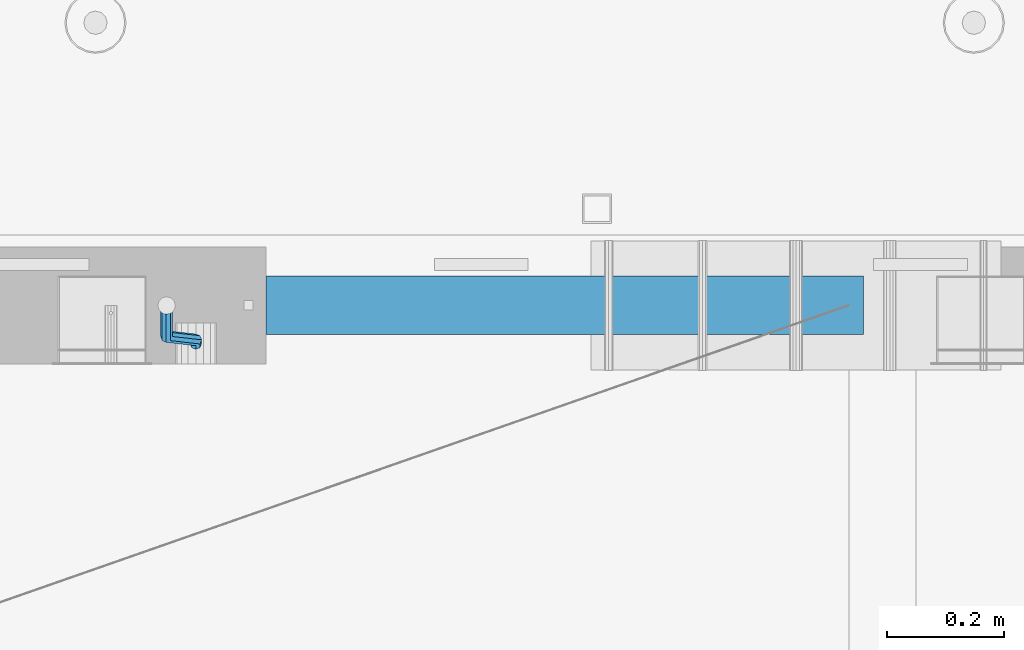
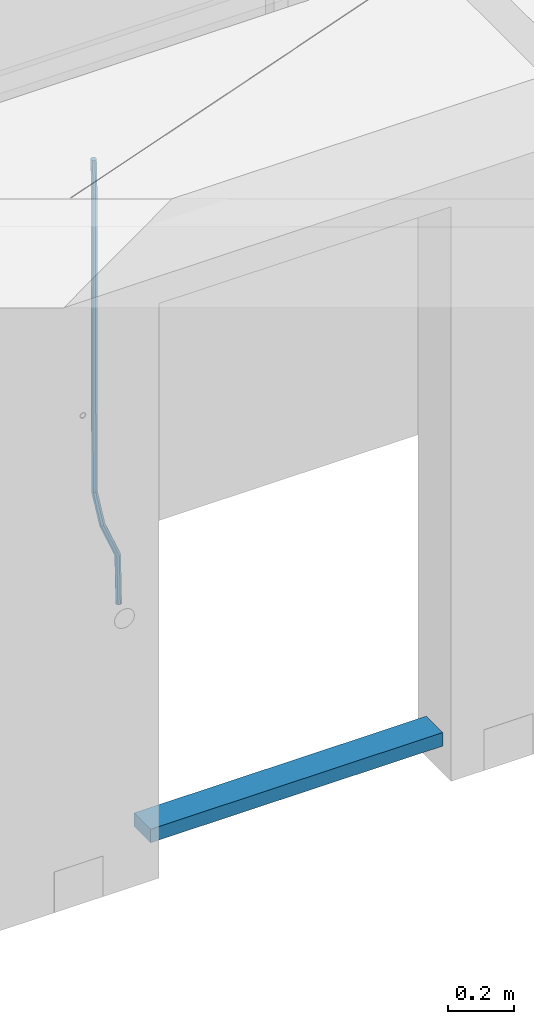
# One storey, part 112 of 350: 2 beams, 1 element without a shape of its own.
"""IFC2X3 building model written with IfcOpenShell, lengths in millimetres."""

from ifc_helpers import new_model, si_unit, frame, origin_with_axes, place, context, subcontext, project, spatial, faceted_brep, material, type_object, element, aggregate, save


model = new_model("IFC2X3")

# Units and contexts
model_context = context("Model", 3, precision=1e-05, world=origin_with_axes())
body_context = subcontext(model_context, "Body", "Model", "MODEL_VIEW")
ifc_project = project(units=[si_unit("LENGTHUNIT", "METRE", prefix="MILLI"), si_unit("AREAUNIT", "SQUARE_METRE"), si_unit("VOLUMEUNIT", "CUBIC_METRE"), si_unit("MASSUNIT", "GRAM", prefix="KILO"), si_unit("TIMEUNIT", "SECOND"), si_unit("PLANEANGLEUNIT", "RADIAN"), si_unit("SOLIDANGLEUNIT", "STERADIAN"), si_unit("THERMODYNAMICTEMPERATUREUNIT", "DEGREE_CELSIUS"), si_unit("LUMINOUSINTENSITYUNIT", "LUMEN")], contexts=[model_context])

# Site, building, storey
site_placement = place(None, origin_with_axes())
site = spatial("IfcSite", under=ifc_project, at=site_placement, CompositionType="ELEMENT")
building_placement = place(site_placement, origin_with_axes())
building = spatial("IfcBuilding", under=site, at=building_placement, CompositionType="ELEMENT")
storey_placement = place(building_placement, origin_with_axes())
storey = spatial("IfcBuildingStorey", under=building, at=storey_placement, Name="2", CompositionType="ELEMENT", Elevation=0.0)

# Assembly, beams
assembly_placement = place(storey_placement, origin_with_axes())
assembly = element("IfcElementAssembly", 1, at=assembly_placement, inside=storey, AssemblyPlace="NOTDEFINED", PredefinedType="REINFORCEMENT_UNIT")
ifc_material_1 = material()
beam_type_1 = type_object("IfcBeamType", Name="D20", PredefinedType="NOTDEFINED")
beam_1_placement = place(assembly_placement, frame((24379.9991455117, 15114.989587991, 85790.0076324386), z_axis=(-0.000205762999925498, 0.999642804629538, -0.0267249099901004), x_axis=(4.30000201928125e-08, 0.0267249099948059, 0.999642825806181)))
beam_1 = element("IfcBeam", 2, at=beam_1_placement, type_object=beam_type_1, material=ifc_material_1, Name="JM20", ObjectType="D20", context=body_context, shape_type="Brep", body=[
    faceted_brep([(0.0, -10.0, 0.0), (-4.19531716033816e-08, -7.07106781186667, -7.07106781187031), (60.4266690400545, -7.0710677960451, -7.07106780570757), (60.4266690441291, -9.99999998418934, 6.15546014159918e-09), (0.0, 0.0, -10.0), (60.426669036824, 1.58106558956206e-08, -9.99999999384454), (4.196772351861e-08, 7.07106781186303, -7.07106781186667), (60.4266690363438, 7.07106782768096, -7.07106780570757), (0.0, 10.0, 0.0), (60.4266690388904, 10.0000000158179, 6.15182216279209e-09), (4.196772351861e-08, 7.07106781185939, 7.07106781185939), (60.4266690429649, 7.07106782768096, 7.07106781802577), (0.0, 0.0, 10.0), (60.4266690461809, 1.58179318532348e-08, 10.0000000061555), (-4.19531716033816e-08, -7.07106781187031, 7.07106781185939), (60.4266690466611, -7.07106779605238, 7.07106781802213), (61.0378400410118, -7.07106779588503, -7.07106780564936), (60.991799419251, -9.99999998403655, 6.21366780251265e-09), (61.0569027789461, 1.5985278878361e-08, -9.99999999378269), (61.0378209396877, 7.07106782784831, -7.07106780564936), (60.9917724058905, 10.0000000159635, 6.21366780251265e-09), (60.9457317841297, 7.07106782781193, 7.0710678180767), (60.9266690461809, 1.59488990902901e-08, 10.0000000062028), (60.9457508854539, -7.07106779591413, 7.0710678180767), (61.6489592143771, -7.07106614513759, -7.06310863441468), (61.5568818710308, -9.9999984576425, 0.00735959856683621), (61.6870830769039, 1.71821739058942e-06, -9.99179257185824), (61.6489210170112, 7.07106947854481, -7.06310888312146), (61.556827851804, 10.0000015422847, 0.00735924683976918), (61.4647505084577, 7.07106922979438, 7.07782747982128), (61.4266266459163, 1.36643211590126e-06, 10.0065114172685), (61.464788705809, -7.07106639389531, 7.07782772852806), (174.621213165461, -7.07076098345351, -5.59176629582907), (174.529135822144, -9.99969329595478, 1.4787019371488), (174.659337027944, 0.000306879905110691, -8.52045023327446), (174.621174967935, 7.07137464022526, -5.59176654453404), (174.529081802684, 10.0003067039688, 1.47870158543083), (174.437004459352, 7.07137439147118, 8.5491698184087), (174.398880596913, 0.000306528108922066, 11.4778537558541), (174.437042656878, -7.07076123221123, 8.54917006711185), (175.716094779258, -7.07075802595864, -5.57750663810293), (175.029093421879, -9.99969194546793, 1.48521334821271), (177.145578432857, 0.000313595744955819, -8.48806960781258), (178.480172245545, 7.07138506415868, -5.54150724740612), (178.938089262141, 10.0003186135946, 1.53612417477052), (178.251087904748, 7.07138469408164, 8.59884416108434), (176.821604251149, 0.000313072378048673, 11.5094071307958), (175.487010438475, -7.07075839603567, 8.56284477038935), (176.73028205616, -7.48306481911277, -5.5575978012148), (175.49220343327, -10.1879642774365, 1.49430435328395), (179.448580299344, -0.935946733912715, -8.44286090764945), (182.054755918522, 5.61817699831226, -5.47133696928722), (183.022146581905, 8.33998958468874, 1.61629559169705), (181.784067959001, 5.63509012636496, 8.6681977461958), (179.065769715831, -0.912027958831459, 11.5534608526305), (176.459594096654, -7.4661516910528, 8.58193691426459), (294.295456565174, -55.2779062578775, -3.24975393820569), (293.057377942285, -57.9828057162013, 3.80214821629306), (297.013754808359, -48.7307881726811, -6.13501704463852), (299.619930427536, -42.1766644404597, -3.16349310627629), (300.587321090919, -39.454851854076, 3.92413945470616), (299.34924246803, -42.1597513124034, 10.9760416092031), (296.630944224846, -48.7068693975998, 13.8613047156396), (294.024768605668, -55.2609931298248, 10.8897807772755), (300.131186042752, -57.6503585272258, -3.13519660847487), (297.927214299008, -59.9625846556301, 3.89774473963917), (302.241773597852, -50.8561822796182, -6.0323892798333), (303.022623399127, -43.5599922135116, -3.09669710035814), (302.016324223136, -40.0357975159677, 3.95219126616212), (299.812352479406, -42.3480236443684, 10.9851326142743), (297.701764924292, -49.1421998919686, 13.8823252856328), (296.920915123032, -56.4383899580826, 10.9466331061594), (305.816309115588, -57.6497962814865, -0.41917616768842), (302.671371672826, -59.9621154692577, 6.16422661461002), (307.334869561208, -50.8556785840192, -3.59920488503303), (306.337500895927, -43.5596643796707, -1.51304184353285), (303.408448157163, -40.0356598380822, 4.61726694041863), (300.263510714387, -42.3479790258461, 11.2006697227207), (298.744950268767, -49.1420967233171, 14.3806984400617), (299.742318934063, -56.4381109276655, 12.2945353985633), (395.630203780689, -57.6409138916788, 42.488667805259), (392.485266337913, -59.9532330794427, 49.0720705875574), (397.148764226309, -50.8467961942151, 39.3086390879143), (396.151395561013, -43.5507819898594, 41.3948021294145), (393.22234282225, -40.0267774482672, 47.5251109133696), (390.077405379474, -42.3390966360348, 54.1085136956717), (388.558844933854, -49.1332143335057, 57.2885424130127), (389.556213599149, -56.4292285378579, 55.2023793715125), (396.844209099741, -57.640793829316, 43.0686487871244), (395.280625423067, -59.9529566247911, 50.4075302279853), (397.599922461304, -50.8467515756856, 39.5241761963625), (397.10507886979, -43.5506876727486, 41.8504164279075), (395.649550989881, -40.0265374029004, 48.6846895034632), (394.085967313207, -42.3387001983865, 56.0235709443259), (393.330253951674, -49.1327424520096, 59.5680435350878), (393.825097543173, -56.4288063549466, 57.241803303541), (398.189189358192, -57.6411602552034, 43.0337942646147), (398.377566371972, -59.9538003541529, 50.3272744790011), (398.099754636642, -50.8468877497689, 39.5112232837091), (398.161651854258, -43.550975525075, 41.8230358424771), (398.338622460418, -40.027270012466, 48.6150034976581), (398.526999474212, -42.3399101114192, 55.9084837120445), (398.616434195777, -49.13418261685, 59.4310546929501), (398.554536978161, -56.4300948415512, 57.1192421341821), (1517.19478070838, -57.9460216934422, 14.0352975759452), (1517.38315772217, -60.2586617923953, 21.3287777903333), (1517.10534598683, -51.1517491880113, 10.5127265950414), (1517.16724320444, -43.8558369633138, 12.8245391538094), (1517.34421381062, -40.3321314507048, 19.6165068089904), (1517.53259082441, -42.6447715496579, 26.9099870233767), (1517.62202554596, -49.4390440550887, 30.4325580042841), (1517.56012832835, -56.7349562797899, 28.1207454455143), (1518.02724982343, -57.946248491, 14.0137245355054), (1518.07759034891, -60.258850983344, 21.3107818997123), (1517.99524544395, -51.1519916318648, 10.4896652746502), (1518.00032494192, -43.8560639277712, 12.8029502375484), (1518.03951281632, -40.3323208776928, 19.5984884665704), (1518.08985334181, -42.6449233700369, 26.8955458307773), (1518.12185772131, -49.4391802291757, 30.4196050916289), (1518.11677822332, -56.735107933262, 28.1063201287325), (1518.85992470267, -57.9437654472204, 14.0245252313944), (1518.77219462092, -60.2567796673247, 21.3197916701429), (1518.8853648605, -51.149337287974, 10.5012110884654), (1518.83361259502, -43.8535790567003, 12.8137588817826), (1518.73498368141, -40.3302469774862, 19.6075094776534), (1518.64725359967, -42.6432611975906, 26.9027759164019), (1518.62181344185, -49.4376893568369, 30.4260900593326), (1518.67356570732, -56.7334475881107, 28.1135422660154), (1618.76572350181, -57.6458454809253, 15.3204117501973), (1618.67799342007, -59.9588597010261, 22.6156781889458), (1618.79116365965, -50.8514173216718, 11.7970976072666), (1618.73941139416, -43.5556590904016, 14.1096454005838), (1618.64078248056, -40.032327011184, 20.9033959964545), (1618.55305239883, -42.3453412312883, 28.198662435203), (1618.52761224099, -49.1397693905419, 31.7219765781338), (1618.57936450648, -56.4355276218121, 29.4094287848166)], [[[0, 1, 2, 3]], [[1, 4, 5, 2]], [[4, 6, 7, 5]], [[6, 8, 9, 7]], [[8, 10, 11, 9]], [[10, 12, 13, 11]], [[12, 14, 15, 13]], [[14, 0, 3, 15]], [[14, 12, 10, 8, 6, 4, 1, 0]], [[3, 2, 16, 17]], [[2, 5, 18, 16]], [[5, 7, 19, 18]], [[7, 9, 20, 19]], [[9, 11, 21, 20]], [[11, 13, 22, 21]], [[13, 15, 23, 22]], [[15, 3, 17, 23]], [[17, 16, 24, 25]], [[16, 18, 26, 24]], [[18, 19, 27, 26]], [[19, 20, 28, 27]], [[20, 21, 29, 28]], [[21, 22, 30, 29]], [[22, 23, 31, 30]], [[23, 17, 25, 31]], [[25, 24, 32, 33]], [[24, 26, 34, 32]], [[26, 27, 35, 34]], [[27, 28, 36, 35]], [[28, 29, 37, 36]], [[29, 30, 38, 37]], [[30, 31, 39, 38]], [[31, 25, 33, 39]], [[33, 32, 40, 41]], [[32, 34, 42, 40]], [[34, 35, 43, 42]], [[35, 36, 44, 43]], [[36, 37, 45, 44]], [[37, 38, 46, 45]], [[38, 39, 47, 46]], [[39, 33, 41, 47]], [[41, 40, 48, 49]], [[40, 42, 50, 48]], [[42, 43, 51, 50]], [[43, 44, 52, 51]], [[44, 45, 53, 52]], [[45, 46, 54, 53]], [[46, 47, 55, 54]], [[47, 41, 49, 55]], [[49, 48, 56, 57]], [[48, 50, 58, 56]], [[50, 51, 59, 58]], [[51, 52, 60, 59]], [[52, 53, 61, 60]], [[53, 54, 62, 61]], [[54, 55, 63, 62]], [[55, 49, 57, 63]], [[57, 56, 64, 65]], [[56, 58, 66, 64]], [[58, 59, 67, 66]], [[59, 60, 68, 67]], [[60, 61, 69, 68]], [[61, 62, 70, 69]], [[62, 63, 71, 70]], [[63, 57, 65, 71]], [[65, 64, 72, 73]], [[64, 66, 74, 72]], [[66, 67, 75, 74]], [[67, 68, 76, 75]], [[68, 69, 77, 76]], [[69, 70, 78, 77]], [[70, 71, 79, 78]], [[71, 65, 73, 79]], [[73, 72, 80, 81]], [[72, 74, 82, 80]], [[74, 75, 83, 82]], [[75, 76, 84, 83]], [[76, 77, 85, 84]], [[77, 78, 86, 85]], [[78, 79, 87, 86]], [[79, 73, 81, 87]], [[81, 80, 88, 89]], [[80, 82, 90, 88]], [[82, 83, 91, 90]], [[83, 84, 92, 91]], [[84, 85, 93, 92]], [[85, 86, 94, 93]], [[86, 87, 95, 94]], [[87, 81, 89, 95]], [[89, 88, 96, 97]], [[88, 90, 98, 96]], [[90, 91, 99, 98]], [[91, 92, 100, 99]], [[92, 93, 101, 100]], [[93, 94, 102, 101]], [[94, 95, 103, 102]], [[95, 89, 97, 103]], [[97, 96, 104, 105]], [[96, 98, 106, 104]], [[98, 99, 107, 106]], [[99, 100, 108, 107]], [[100, 101, 109, 108]], [[101, 102, 110, 109]], [[102, 103, 111, 110]], [[103, 97, 105, 111]], [[105, 104, 112, 113]], [[104, 106, 114, 112]], [[106, 107, 115, 114]], [[107, 108, 116, 115]], [[108, 109, 117, 116]], [[109, 110, 118, 117]], [[110, 111, 119, 118]], [[111, 105, 113, 119]], [[113, 112, 120, 121]], [[112, 114, 122, 120]], [[114, 115, 123, 122]], [[115, 116, 124, 123]], [[116, 117, 125, 124]], [[117, 118, 126, 125]], [[118, 119, 127, 126]], [[119, 113, 121, 127]], [[121, 120, 128, 129]], [[120, 122, 130, 128]], [[122, 123, 131, 130]], [[123, 124, 132, 131]], [[124, 125, 133, 132]], [[125, 126, 134, 133]], [[126, 127, 135, 134]], [[127, 121, 129, 135]], [[130, 131, 132, 133, 134, 135, 129, 128]]]),
])
ifc_material_2 = material(Name="TIMBER/T24")
beam_type_2 = type_object("IfcBeamType", PredefinedType="NOTDEFINED")
beam_2_placement = place(assembly_placement, frame((24500.0006866455, 15180.0, 84880.0), z_axis=(0.0, 0.0, 1.0), x_axis=(1.0, 0.0, 0.0)))
beam_2 = element("IfcBeam", 3, at=beam_2_placement, type_object=beam_type_2, material=ifc_material_2, context=body_context, shape_type="Brep", body=[
    faceted_brep([(0.0, 50.0, -25.0), (0.0, 50.0, 25.0), (1020.0, 50.0, 25.0), (1020.0, 50.0, -25.0), (0.0, -50.0, 25.0), (1020.0, -50.0, 25.0), (0.0, -50.0, -25.0), (1020.0, -50.0, -25.0)], [[[0, 1, 2, 3]], [[1, 4, 5, 2]], [[4, 6, 7, 5]], [[6, 0, 3, 7]], [[5, 7, 3, 2]], [[6, 4, 1, 0]]]),
])
aggregate(assembly, [beam_1, beam_2])

save(model, "model.ifc")
